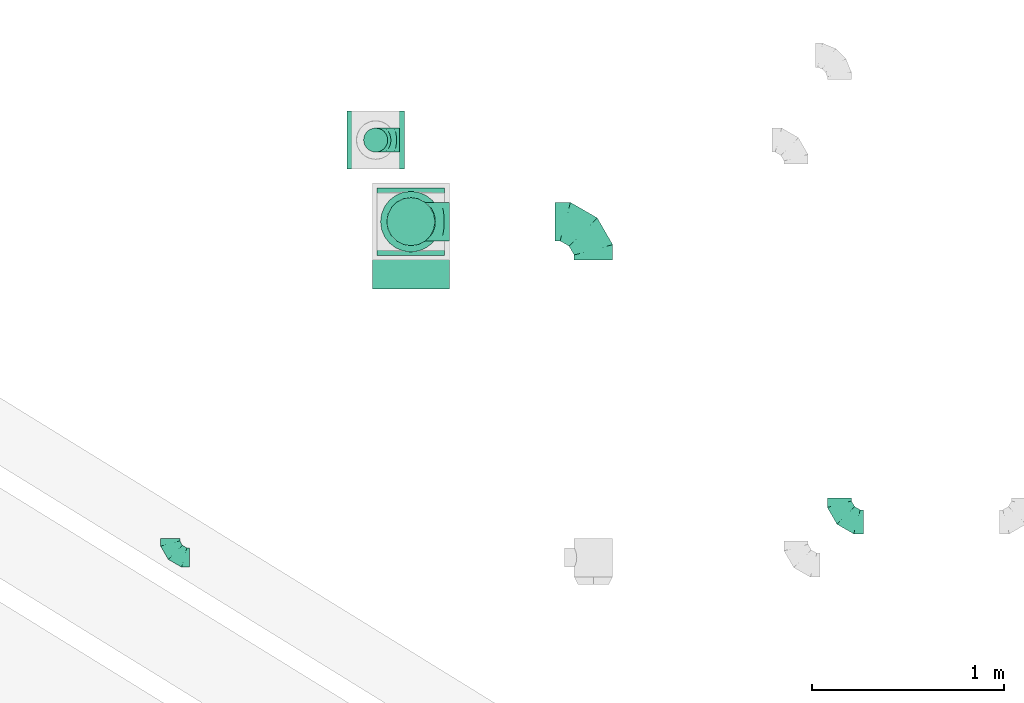
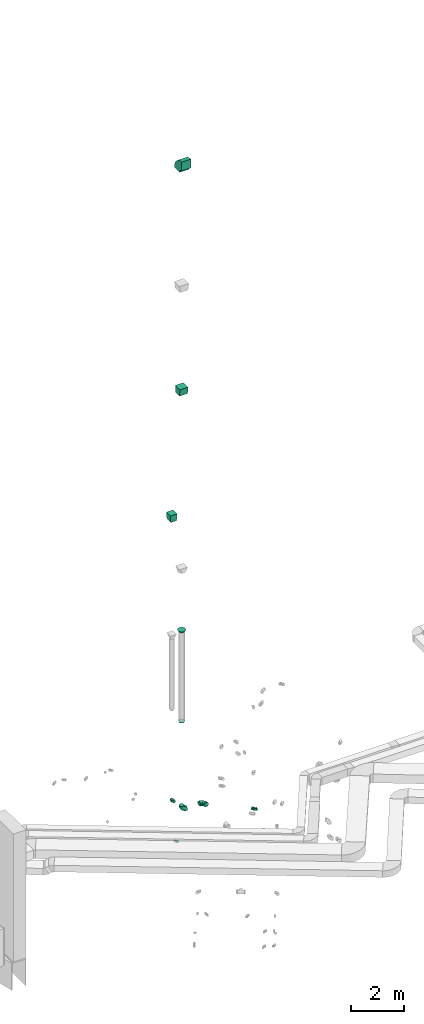
# One storey, part 38 of 97: 10 flow fittings.
"""IFC2X3 building model written with IfcOpenShell, lengths in millimetres."""

from ifc_helpers import new_model, entity, si_unit, converted_unit, derived_unit, direction, frame, frame_2d, origin, place, context, subcontext, project, spatial, polyline, circle_curve, parameter, trimmed, segment, composite_curve, outline, extrude, faceted_brep, source, transform, mapped, material, type_object, type_shapes, element, save


model = new_model("IFC2X3")

# Units and contexts
model_context = context("Model", 3, precision=0.01, world=origin(), true_north=direction((6.12303176911189e-17, 1.0)))
body_context = subcontext(model_context, "Body", "Model", "MODEL_VIEW")
ifc_project = project(units=[si_unit("LENGTHUNIT", "METRE", prefix="MILLI"), si_unit("AREAUNIT", "SQUARE_METRE"), si_unit("VOLUMEUNIT", "CUBIC_METRE"), converted_unit("PLANEANGLEUNIT", "DEGREE", entity("IfcRatioMeasure", 0.0174532925199433), si_unit("PLANEANGLEUNIT", "RADIAN"), dimensions=[0, 0, 0, 0, 0, 0, 0]), si_unit("MASSUNIT", "GRAM", prefix="KILO"), derived_unit("MASSDENSITYUNIT", [(si_unit("MASSUNIT", "GRAM", prefix="KILO"), 1), (si_unit("LENGTHUNIT", "METRE"), -3)]), derived_unit("MOMENTOFINERTIAUNIT", [(si_unit("LENGTHUNIT", "METRE"), 4)]), si_unit("TIMEUNIT", "SECOND"), si_unit("FREQUENCYUNIT", "HERTZ"), si_unit("THERMODYNAMICTEMPERATUREUNIT", "DEGREE_CELSIUS"), derived_unit("THERMALTRANSMITTANCEUNIT", [(si_unit("MASSUNIT", "GRAM", prefix="KILO"), 1), (si_unit("THERMODYNAMICTEMPERATUREUNIT", "KELVIN"), -1), (si_unit("TIMEUNIT", "SECOND"), -3)]), derived_unit("VOLUMETRICFLOWRATEUNIT", [(si_unit("LENGTHUNIT", "METRE"), 3), (si_unit("TIMEUNIT", "SECOND"), -1)]), derived_unit("MASSFLOWRATEUNIT", [(si_unit("MASSUNIT", "GRAM", prefix="KILO"), 1), (si_unit("TIMEUNIT", "SECOND"), -1)]), derived_unit("ROTATIONALFREQUENCYUNIT", [(si_unit("TIMEUNIT", "SECOND"), -1)]), si_unit("ELECTRICCURRENTUNIT", "AMPERE"), si_unit("ELECTRICVOLTAGEUNIT", "VOLT"), si_unit("POWERUNIT", "WATT"), si_unit("FORCEUNIT", "NEWTON", prefix="KILO"), si_unit("ILLUMINANCEUNIT", "LUX"), si_unit("LUMINOUSFLUXUNIT", "LUMEN"), si_unit("LUMINOUSINTENSITYUNIT", "CANDELA"), derived_unit("USERDEFINED", [(si_unit("MASSUNIT", "GRAM", prefix="KILO"), -1), (si_unit("LENGTHUNIT", "METRE"), -2), (si_unit("TIMEUNIT", "SECOND"), 3), (si_unit("LUMINOUSFLUXUNIT", "LUMEN"), 1)]), derived_unit("LINEARVELOCITYUNIT", [(si_unit("LENGTHUNIT", "METRE"), 1), (si_unit("TIMEUNIT", "SECOND"), -1)]), si_unit("PRESSUREUNIT", "PASCAL"), derived_unit("USERDEFINED", [(si_unit("LENGTHUNIT", "METRE"), -2), (si_unit("MASSUNIT", "GRAM", prefix="KILO"), 1), (si_unit("TIMEUNIT", "SECOND"), -2)]), derived_unit("LINEARFORCEUNIT", [(si_unit("MASSUNIT", "GRAM", prefix="KILO"), 1), (si_unit("LENGTHUNIT", "METRE"), 1), (si_unit("TIMEUNIT", "SECOND"), -2), (si_unit("LENGTHUNIT", "METRE"), -1)]), derived_unit("PLANARFORCEUNIT", [(si_unit("MASSUNIT", "GRAM", prefix="KILO"), 1), (si_unit("LENGTHUNIT", "METRE"), 1), (si_unit("TIMEUNIT", "SECOND"), -2), (si_unit("LENGTHUNIT", "METRE"), -2)])], contexts=[model_context])

# Site, building, storey
site_placement = place(None, origin())
site = spatial("IfcSite", under=ifc_project, at=site_placement, CompositionType="ELEMENT")
building_placement = place(site_placement, origin())
building = spatial("IfcBuilding", under=site, at=building_placement, CompositionType="ELEMENT")
storey_placement = place(building_placement, frame((0.0, 0.0, -4900.0)))
storey = spatial("IfcBuildingStorey", under=building, at=storey_placement, CompositionType="ELEMENT", Elevation=-4900.0)

# Flow fittings
ifc_material = material()
duct_fitting_type_1 = type_object("IfcDuctFittingType", PredefinedType="NOTDEFINED", material=ifc_material)
shared_shape_1 = source(origin(), body_context, "Body", "SweptSolid", [
    extrude(outline(polyline([(-139.1, -137.03), (161.94, -137.03), (137.03, 161.94), (-159.86, 112.11), (-139.1, -137.03)])), frame((150.0, -149.99, 0.0), z_axis=(-5.48503268975493e-05, 1.0, 0.0), x_axis=(0.996545756756143, 5.46608606086653e-05, 0.0830454797295822)), (5.46608606086653e-05, 4.55507171053196e-06, 1.0), 300.0),
])
type_shapes(duct_fitting_type_1, [shared_shape_1])
flow_fitting_1_placement = place(storey_placement, frame((8021.67, 14359.63, 16995.0), z_axis=(-1.0, 0.0, 0.0), x_axis=(0.0, 0.0, 1.0)))
element("IfcFlowFitting", 1, at=flow_fitting_1_placement, inside=storey, type_object=duct_fitting_type_1, material=ifc_material, context=body_context, shape_type="MappedRepresentation", body=[
    mapped(shared_shape_1, transform((0.0, 0.0, 0.0), scale=1.0)),
])
duct_fitting_type_2 = type_object("IfcDuctFittingType", PredefinedType="NOTDEFINED", material=ifc_material)
shared_shape_2 = source(origin(), body_context, "Body", "SweptSolid", [
    extrude(outline(polyline([(-137.03, -161.94), (164.01, -161.94), (134.95, 186.85), (-161.94, 137.03), (-137.03, -161.94)])), frame((150.0, 0.0, -175.0), z_axis=(0.0, 0.0, 1.0), x_axis=(0.996545758244879, -0.0830454798537418, 0.0)), (0.0, 0.0, 1.0), 350.0),
])
type_shapes(duct_fitting_type_2, [shared_shape_2])
flow_fitting_2_placement = place(storey_placement, frame((8204.69, 13935.69, 22980.0), z_axis=(-1.0, 0.0, 0.0), x_axis=(0.0, 0.0, 1.0)))
element("IfcFlowFitting", 2, at=flow_fitting_2_placement, inside=storey, type_object=duct_fitting_type_2, material=ifc_material, context=body_context, shape_type="MappedRepresentation", body=[
    mapped(shared_shape_2, transform((0.0, 0.0, 0.0), scale=1.0)),
])
duct_fitting_type_3 = type_object("IfcDuctFittingType", PredefinedType="NOTDEFINED", material=ifc_material)
shared_shape_3 = source(origin(), body_context, "Body", "Brep", [
    faceted_brep([(-100.0, 0.0, -50.0), (-100.0, -12.94, -48.3), (-100.0, -25.0, -43.3), (-100.0, -35.36, -35.36), (-100.0, -43.3, -25.0), (-100.0, -48.3, -12.94), (-100.0, -50.0, 0.0), (-100.0, -48.3, 12.94), (-100.0, -43.3, 25.0), (-100.0, -35.36, 35.36), (-100.0, -25.0, 43.3), (-100.0, -12.94, 48.3), (-100.0, 0.0, 50.0), (-100.0, 12.94, 48.3), (-100.0, 25.0, 43.3), (-100.0, 35.36, 35.36), (-100.0, 43.3, 25.0), (-100.0, 48.3, 12.94), (-100.0, 50.0, 0.0), (-100.0, 48.3, -12.94), (-100.0, 43.3, -25.0), (-100.0, 35.36, -35.36), (-100.0, 25.0, -43.3), (-100.0, 12.94, -48.3), (-76.67, 12.94, 48.3), (-79.9, 25.0, 43.3), (-73.21, 0.0, 50.0), (-82.68, 35.36, 35.36), (-86.15, 48.3, 12.94), (-86.6, 50.0, 0.0), (-84.81, 43.3, 25.0), (-84.81, 43.3, -25.0), (-82.68, 35.36, -35.36), (-86.15, 48.3, -12.94), (-76.67, 12.94, -48.3), (-73.21, 0.0, -50.0), (-79.9, 25.0, -43.3), (-69.74, -12.94, -48.3), (-66.51, -25.0, -43.3), (-63.73, -35.36, -35.36), (-61.6, -43.3, -25.0), (-60.26, -48.3, -12.94), (-59.81, -50.0, 0.0), (-60.26, -48.3, 12.94), (-61.6, -43.3, 25.0), (-63.73, -35.36, 35.36), (-66.51, -25.0, 43.3), (-69.74, -12.94, 48.3), (-36.27, 36.27, 48.3), (-45.1, 45.1, 43.3), (-26.79, 26.79, 50.0), (-52.68, 52.68, 35.36), (-58.49, 58.49, 25.0), (-62.15, 62.15, 12.94), (-63.4, 63.4, 0.0), (-62.15, 62.15, -12.94), (-58.49, 58.49, -25.0), (-52.68, 52.68, -35.36), (-36.27, 36.27, -48.3), (-26.79, 26.79, -50.0), (-45.1, 45.1, -43.3), (-17.32, 17.32, -48.3), (-8.49, 8.49, -43.3), (-0.91, 0.91, -35.36), (4.9, -4.9, -25.0), (8.56, -8.56, -12.94), (9.81, -9.81, 0.0), (8.56, -8.56, 12.94), (4.9, -4.9, 25.0), (-0.91, 0.91, 35.36), (-8.49, 8.49, 43.3), (-17.32, 17.32, 48.3), (-12.94, 76.67, 48.3), (-25.0, 79.9, 43.3), (0.0, 73.21, 50.0), (-35.36, 82.68, 35.36), (-43.3, 84.81, 25.0), (-48.3, 86.15, 12.94), (-50.0, 86.6, 0.0), (-48.3, 86.15, -12.94), (-43.3, 84.81, -25.0), (-35.36, 82.68, -35.36), (-12.94, 76.67, -48.3), (0.0, 73.21, -50.0), (-25.0, 79.9, -43.3), (12.94, 69.74, -48.3), (25.0, 66.51, -43.3), (35.36, 63.73, -35.36), (43.3, 61.6, -25.0), (48.3, 60.26, -12.94), (50.0, 59.81, 0.0), (48.3, 60.26, 12.94), (43.3, 61.6, 25.0), (35.36, 63.73, 35.36), (25.0, 66.51, 43.3), (12.94, 69.74, 48.3), (-12.94, 100.0, -48.3), (-25.0, 100.0, -43.3), (-35.36, 100.0, -35.36), (-43.3, 100.0, -25.0), (-48.3, 100.0, -12.94), (-50.0, 100.0, 0.0), (-48.3, 100.0, 12.94), (-43.3, 100.0, 25.0), (-35.36, 100.0, 35.36), (-25.0, 100.0, 43.3), (-12.94, 100.0, 48.3), (0.0, 100.0, 50.0), (12.94, 100.0, 48.3), (25.0, 100.0, 43.3), (35.36, 100.0, 35.36), (43.3, 100.0, 25.0), (48.3, 100.0, 12.94), (50.0, 100.0, 0.0), (48.3, 100.0, -12.94), (43.3, 100.0, -25.0), (35.36, 100.0, -35.36), (25.0, 100.0, -43.3), (12.94, 100.0, -48.3), (0.0, 100.0, -50.0)], [[[0, 1, 2, 3, 4, 5, 6, 7, 8, 9, 10, 11, 12, 13, 14, 15, 16, 17, 18, 19, 20, 21, 22, 23]], [[24, 25, 14, 13]], [[26, 24, 13, 12]], [[14, 25, 27, 15]], [[28, 29, 18, 17]], [[30, 28, 17, 16]], [[15, 27, 30, 16]], [[20, 31, 32, 21]], [[33, 31, 20, 19]], [[18, 29, 33, 19]], [[34, 35, 0, 23]], [[36, 34, 23, 22]], [[32, 36, 22, 21]], [[2, 1, 37, 38]], [[3, 2, 38, 39]], [[0, 35, 37, 1]], [[5, 4, 40, 41]], [[6, 5, 41, 42]], [[3, 39, 40, 4]], [[6, 42, 43, 7]], [[7, 43, 44, 8]], [[8, 44, 45, 9]], [[10, 46, 47, 11]], [[11, 47, 26, 12]], [[10, 9, 45, 46]], [[48, 49, 25, 24]], [[50, 48, 24, 26]], [[27, 25, 49, 51]], [[52, 53, 28, 30]], [[51, 52, 30, 27]], [[29, 28, 53, 54]], [[55, 56, 31, 33]], [[54, 55, 33, 29]], [[57, 32, 31, 56]], [[58, 59, 35, 34]], [[60, 58, 34, 36]], [[57, 60, 36, 32]], [[37, 35, 59, 61]], [[38, 37, 61, 62]], [[39, 38, 62, 63]], [[41, 40, 64, 65]], [[42, 41, 65, 66]], [[63, 64, 40, 39]], [[43, 42, 66, 67]], [[44, 43, 67, 68]], [[68, 69, 45, 44]], [[46, 45, 69, 70]], [[47, 46, 70, 71]], [[26, 47, 71, 50]], [[72, 73, 49, 48]], [[74, 72, 48, 50]], [[51, 49, 73, 75]], [[76, 77, 53, 52]], [[75, 76, 52, 51]], [[54, 53, 77, 78]], [[79, 80, 56, 55]], [[78, 79, 55, 54]], [[81, 57, 56, 80]], [[82, 83, 59, 58]], [[84, 82, 58, 60]], [[81, 84, 60, 57]], [[61, 59, 83, 85]], [[62, 61, 85, 86]], [[63, 62, 86, 87]], [[65, 64, 88, 89]], [[66, 65, 89, 90]], [[87, 88, 64, 63]], [[67, 66, 90, 91]], [[68, 67, 91, 92]], [[92, 93, 69, 68]], [[70, 69, 93, 94]], [[71, 70, 94, 95]], [[50, 71, 95, 74]], [[96, 97, 98, 99, 100, 101, 102, 103, 104, 105, 106, 107, 108, 109, 110, 111, 112, 113, 114, 115, 116, 117, 118, 119]], [[72, 74, 107, 106]], [[73, 72, 106, 105]], [[75, 73, 105, 104]], [[77, 76, 103, 102]], [[78, 77, 102, 101]], [[75, 104, 103, 76]], [[78, 101, 100, 79]], [[79, 100, 99, 80]], [[80, 99, 98, 81]], [[96, 119, 83, 82]], [[97, 96, 82, 84]], [[84, 81, 98, 97]], [[83, 119, 118, 85]], [[85, 118, 117, 86]], [[86, 117, 116, 87]], [[88, 115, 114, 89]], [[89, 114, 113, 90]], [[87, 116, 115, 88]], [[91, 90, 113, 112]], [[92, 91, 112, 111]], [[93, 92, 111, 110]], [[95, 94, 109, 108]], [[74, 95, 108, 107]], [[110, 109, 94, 93]]]),
])
type_shapes(duct_fitting_type_3, [shared_shape_3])
flow_fitting_3_placement = place(storey_placement, frame((6954.03, 12190.19, 3950.0), z_axis=(0.0, 0.0, 1.0), x_axis=(0.0, -1.0, 0.0)))
element("IfcFlowFitting", 3, at=flow_fitting_3_placement, inside=storey, type_object=duct_fitting_type_3, material=ifc_material, context=body_context, shape_type="MappedRepresentation", body=[
    mapped(shared_shape_3, transform((0.0, 0.0, 0.0), scale=1.0)),
])
duct_fitting_type_4 = type_object("IfcDuctFittingType", PredefinedType="NOTDEFINED", material=ifc_material)
shared_shape_4 = source(origin(), body_context, "Body", "Brep", [
    faceted_brep([(-200.0, 0.0, -100.0), (-200.0, -25.88, -96.59), (-200.0, -50.0, -86.6), (-200.0, -70.71, -70.71), (-200.0, -86.6, -50.0), (-200.0, -96.59, -25.88), (-200.0, -100.0, 0.0), (-200.0, -96.59, 25.88), (-200.0, -86.6, 50.0), (-200.0, -70.71, 70.71), (-200.0, -50.0, 86.6), (-200.0, -25.88, 96.59), (-200.0, 0.0, 100.0), (-200.0, 25.88, 96.59), (-200.0, 50.0, 86.6), (-200.0, 70.71, 70.71), (-200.0, 86.6, 50.0), (-200.0, 96.59, 25.88), (-200.0, 100.0, 0.0), (-200.0, 96.59, -25.88), (-200.0, 86.6, -50.0), (-200.0, 70.71, -70.71), (-200.0, 50.0, -86.6), (-200.0, 25.88, -96.59), (-153.35, 25.88, 96.59), (-159.81, 50.0, 86.6), (-146.41, 0.0, 100.0), (-165.36, 70.71, 70.71), (-172.29, 96.59, 25.88), (-173.21, 100.0, 0.0), (-169.62, 86.6, 50.0), (-169.62, 86.6, -50.0), (-165.36, 70.71, -70.71), (-172.29, 96.59, -25.88), (-153.35, 25.88, -96.59), (-146.41, 0.0, -100.0), (-159.81, 50.0, -86.6), (-139.48, -25.88, -96.59), (-133.01, -50.0, -86.6), (-127.46, -70.71, -70.71), (-123.21, -86.6, -50.0), (-120.53, -96.59, -25.88), (-119.62, -100.0, 0.0), (-120.53, -96.59, 25.88), (-123.21, -86.6, 50.0), (-127.46, -70.71, 70.71), (-133.01, -50.0, 86.6), (-139.48, -25.88, 96.59), (-72.54, 72.54, 96.59), (-90.19, 90.19, 86.6), (-53.59, 53.59, 100.0), (-105.35, 105.35, 70.71), (-116.99, 116.99, 50.0), (-124.3, 124.3, 25.88), (-126.79, 126.79, 0.0), (-124.3, 124.3, -25.88), (-116.99, 116.99, -50.0), (-105.35, 105.35, -70.71), (-72.54, 72.54, -96.59), (-53.59, 53.59, -100.0), (-90.19, 90.19, -86.6), (-34.64, 34.64, -96.59), (-16.99, 16.99, -86.6), (-1.83, 1.83, -70.71), (9.81, -9.81, -50.0), (17.12, -17.12, -25.88), (19.62, -19.62, 0.0), (17.12, -17.12, 25.88), (9.81, -9.81, 50.0), (-1.83, 1.83, 70.71), (-16.99, 16.99, 86.6), (-34.64, 34.64, 96.59), (-25.88, 153.35, 96.59), (-50.0, 159.81, 86.6), (0.0, 146.41, 100.0), (-70.71, 165.36, 70.71), (-86.6, 169.62, 50.0), (-96.59, 172.29, 25.88), (-100.0, 173.21, 0.0), (-96.59, 172.29, -25.88), (-86.6, 169.62, -50.0), (-70.71, 165.36, -70.71), (-25.88, 153.35, -96.59), (0.0, 146.41, -100.0), (-50.0, 159.81, -86.6), (25.88, 139.48, -96.59), (50.0, 133.01, -86.6), (70.71, 127.46, -70.71), (86.6, 123.21, -50.0), (96.59, 120.53, -25.88), (100.0, 119.62, 0.0), (96.59, 120.53, 25.88), (86.6, 123.21, 50.0), (70.71, 127.46, 70.71), (50.0, 133.01, 86.6), (25.88, 139.48, 96.59), (-25.88, 200.0, -96.59), (-50.0, 200.0, -86.6), (-70.71, 200.0, -70.71), (-86.6, 200.0, -50.0), (-96.59, 200.0, -25.88), (-100.0, 200.0, 0.0), (-96.59, 200.0, 25.88), (-86.6, 200.0, 50.0), (-70.71, 200.0, 70.71), (-50.0, 200.0, 86.6), (-25.88, 200.0, 96.59), (0.0, 200.0, 100.0), (25.88, 200.0, 96.59), (50.0, 200.0, 86.6), (70.71, 200.0, 70.71), (86.6, 200.0, 50.0), (96.59, 200.0, 25.88), (100.0, 200.0, 0.0), (96.59, 200.0, -25.88), (86.6, 200.0, -50.0), (70.71, 200.0, -70.71), (50.0, 200.0, -86.6), (25.88, 200.0, -96.59), (0.0, 200.0, -100.0)], [[[0, 1, 2, 3, 4, 5, 6, 7, 8, 9, 10, 11, 12, 13, 14, 15, 16, 17, 18, 19, 20, 21, 22, 23]], [[24, 25, 14, 13]], [[26, 24, 13, 12]], [[14, 25, 27, 15]], [[28, 29, 18, 17]], [[30, 28, 17, 16]], [[15, 27, 30, 16]], [[20, 31, 32, 21]], [[33, 31, 20, 19]], [[18, 29, 33, 19]], [[34, 35, 0, 23]], [[36, 34, 23, 22]], [[32, 36, 22, 21]], [[1, 0, 35, 37]], [[2, 1, 37, 38]], [[38, 39, 3, 2]], [[5, 4, 40, 41]], [[6, 5, 41, 42]], [[39, 40, 4, 3]], [[6, 42, 43, 7]], [[7, 43, 44, 8]], [[8, 44, 45, 9]], [[9, 45, 46, 10]], [[10, 46, 47, 11]], [[26, 12, 11, 47]], [[48, 49, 25, 24]], [[50, 48, 24, 26]], [[27, 25, 49, 51]], [[52, 53, 28, 30]], [[51, 52, 30, 27]], [[29, 28, 53, 54]], [[55, 56, 31, 33]], [[54, 55, 33, 29]], [[32, 31, 56, 57]], [[58, 59, 35, 34]], [[60, 58, 34, 36]], [[57, 60, 36, 32]], [[37, 35, 59, 61]], [[38, 37, 61, 62]], [[39, 38, 62, 63]], [[41, 40, 64, 65]], [[42, 41, 65, 66]], [[63, 64, 40, 39]], [[43, 42, 66, 67]], [[44, 43, 67, 68]], [[68, 69, 45, 44]], [[46, 45, 69, 70]], [[47, 46, 70, 71]], [[26, 47, 71, 50]], [[72, 73, 49, 48]], [[74, 72, 48, 50]], [[51, 49, 73, 75]], [[76, 77, 53, 52]], [[75, 76, 52, 51]], [[54, 53, 77, 78]], [[79, 80, 56, 55]], [[78, 79, 55, 54]], [[57, 56, 80, 81]], [[82, 83, 59, 58]], [[84, 82, 58, 60]], [[81, 84, 60, 57]], [[61, 59, 83, 85]], [[62, 61, 85, 86]], [[63, 62, 86, 87]], [[65, 64, 88, 89]], [[66, 65, 89, 90]], [[87, 88, 64, 63]], [[67, 66, 90, 91]], [[68, 67, 91, 92]], [[92, 93, 69, 68]], [[70, 69, 93, 94]], [[71, 70, 94, 95]], [[50, 71, 95, 74]], [[96, 97, 98, 99, 100, 101, 102, 103, 104, 105, 106, 107, 108, 109, 110, 111, 112, 113, 114, 115, 116, 117, 118, 119]], [[72, 74, 107, 106]], [[73, 72, 106, 105]], [[75, 73, 105, 104]], [[102, 101, 78, 77]], [[103, 102, 77, 76]], [[75, 104, 103, 76]], [[78, 101, 100, 79]], [[79, 100, 99, 80]], [[80, 99, 98, 81]], [[84, 97, 96, 82]], [[82, 96, 119, 83]], [[84, 81, 98, 97]], [[118, 117, 86, 85]], [[119, 118, 85, 83]], [[116, 87, 86, 117]], [[88, 115, 114, 89]], [[89, 114, 113, 90]], [[115, 88, 87, 116]], [[91, 90, 113, 112]], [[92, 91, 112, 111]], [[111, 110, 93, 92]], [[95, 94, 109, 108]], [[74, 95, 108, 107]], [[110, 109, 94, 93]]]),
])
type_shapes(duct_fitting_type_4, [shared_shape_4])
for number, where, z_axis, x_axis in (
    (4, (9153.25, 13935.69, 3950.0), (0.0, 0.0, 1.0), (0.0, 1.0, 0.0)),
    (5, (8204.69, 13935.69, 3950.0), (0.0, 1.0, 0.0), (-1.0, 0.0, 0.0)),
):
    element("IfcFlowFitting", number, at=place(storey_placement, frame(where, z_axis=z_axis, x_axis=x_axis)), inside=storey, type_object=duct_fitting_type_4, material=ifc_material, context=body_context, shape_type="MappedRepresentation", body=[
        mapped(shared_shape_4, transform((0.0, 0.0, 0.0), scale=1.0)),
    ])
duct_fitting_type_5 = type_object("IfcDuctFittingType", PredefinedType="NOTDEFINED", material=ifc_material)
shared_shape_5 = source(origin(), body_context, "Body", "Brep", [
    faceted_brep([(-125.0, 0.0, -62.5), (-125.0, -16.18, -60.37), (-125.0, -31.25, -54.13), (-125.0, -44.19, -44.19), (-125.0, -54.13, -31.25), (-125.0, -60.37, -16.18), (-125.0, -62.5, 0.0), (-125.0, -60.37, 16.18), (-125.0, -54.13, 31.25), (-125.0, -44.19, 44.19), (-125.0, -31.25, 54.13), (-125.0, -16.18, 60.37), (-125.0, 0.0, 62.5), (-125.0, 16.18, 60.37), (-125.0, 31.25, 54.13), (-125.0, 44.19, 44.19), (-125.0, 54.13, 31.25), (-125.0, 60.37, 16.18), (-125.0, 62.5, 0.0), (-125.0, 60.37, -16.18), (-125.0, 54.13, -31.25), (-125.0, 44.19, -44.19), (-125.0, 31.25, -54.13), (-125.0, 16.18, -60.37), (-95.84, 16.18, 60.37), (-99.88, 31.25, 54.13), (-91.51, 0.0, 62.5), (-103.35, 44.19, 44.19), (-107.68, 60.37, 16.18), (-108.25, 62.5, 0.0), (-106.01, 54.13, 31.25), (-106.01, 54.13, -31.25), (-103.35, 44.19, -44.19), (-107.68, 60.37, -16.18), (-95.84, 16.18, -60.37), (-91.51, 0.0, -62.5), (-99.88, 31.25, -54.13), (-87.17, -16.18, -60.37), (-83.13, -31.25, -54.13), (-79.66, -44.19, -44.19), (-77.0, -54.13, -31.25), (-75.33, -60.37, -16.18), (-74.76, -62.5, 0.0), (-75.33, -60.37, 16.18), (-77.0, -54.13, 31.25), (-79.66, -44.19, 44.19), (-83.13, -31.25, 54.13), (-87.17, -16.18, 60.37), (-45.34, 45.34, 60.37), (-56.37, 56.37, 54.13), (-33.49, 33.49, 62.5), (-65.85, 65.85, 44.19), (-73.12, 73.12, 31.25), (-77.69, 77.69, 16.18), (-79.25, 79.25, 0.0), (-77.69, 77.69, -16.18), (-73.12, 73.12, -31.25), (-65.85, 65.85, -44.19), (-45.34, 45.34, -60.37), (-33.49, 33.49, -62.5), (-56.37, 56.37, -54.13), (-21.65, 21.65, -60.37), (-10.62, 10.62, -54.13), (-1.14, 1.14, -44.19), (6.13, -6.13, -31.25), (10.7, -10.7, -16.18), (12.26, -12.26, 0.0), (10.7, -10.7, 16.18), (6.13, -6.13, 31.25), (-1.14, 1.14, 44.19), (-10.62, 10.62, 54.13), (-21.65, 21.65, 60.37), (-16.18, 95.84, 60.37), (-31.25, 99.88, 54.13), (0.0, 91.51, 62.5), (-44.19, 103.35, 44.19), (-54.13, 106.01, 31.25), (-60.37, 107.68, 16.18), (-62.5, 108.25, 0.0), (-60.37, 107.68, -16.18), (-54.13, 106.01, -31.25), (-44.19, 103.35, -44.19), (-16.18, 95.84, -60.37), (0.0, 91.51, -62.5), (-31.25, 99.88, -54.13), (16.18, 87.17, -60.37), (31.25, 83.13, -54.13), (44.19, 79.66, -44.19), (54.13, 77.0, -31.25), (60.37, 75.33, -16.18), (62.5, 74.76, 0.0), (60.37, 75.33, 16.18), (54.13, 77.0, 31.25), (44.19, 79.66, 44.19), (31.25, 83.13, 54.13), (16.18, 87.17, 60.37), (-16.18, 125.0, -60.37), (-31.25, 125.0, -54.13), (-44.19, 125.0, -44.19), (-54.13, 125.0, -31.25), (-60.37, 125.0, -16.18), (-62.5, 125.0, 0.0), (-60.37, 125.0, 16.18), (-54.13, 125.0, 31.25), (-44.19, 125.0, 44.19), (-31.25, 125.0, 54.13), (-16.18, 125.0, 60.37), (0.0, 125.0, 62.5), (16.18, 125.0, 60.37), (31.25, 125.0, 54.13), (44.19, 125.0, 44.19), (54.13, 125.0, 31.25), (60.37, 125.0, 16.18), (62.5, 125.0, 0.0), (60.37, 125.0, -16.18), (54.13, 125.0, -31.25), (44.19, 125.0, -44.19), (31.25, 125.0, -54.13), (16.18, 125.0, -60.37), (0.0, 125.0, -62.5)], [[[0, 1, 2, 3, 4, 5, 6, 7, 8, 9, 10, 11, 12, 13, 14, 15, 16, 17, 18, 19, 20, 21, 22, 23]], [[24, 25, 14, 13]], [[26, 24, 13, 12]], [[14, 25, 27, 15]], [[28, 29, 18, 17]], [[30, 28, 17, 16]], [[15, 27, 30, 16]], [[20, 31, 32, 21]], [[33, 31, 20, 19]], [[18, 29, 33, 19]], [[34, 35, 0, 23]], [[36, 34, 23, 22]], [[21, 32, 36, 22]], [[1, 0, 35, 37]], [[2, 1, 37, 38]], [[38, 39, 3, 2]], [[5, 4, 40, 41]], [[6, 5, 41, 42]], [[39, 40, 4, 3]], [[6, 42, 43, 7]], [[7, 43, 44, 8]], [[45, 9, 8, 44]], [[9, 45, 46, 10]], [[10, 46, 47, 11]], [[26, 12, 11, 47]], [[48, 49, 25, 24]], [[50, 48, 24, 26]], [[27, 25, 49, 51]], [[52, 53, 28, 30]], [[51, 52, 30, 27]], [[29, 28, 53, 54]], [[55, 56, 31, 33]], [[54, 55, 33, 29]], [[57, 32, 31, 56]], [[58, 59, 35, 34]], [[60, 58, 34, 36]], [[57, 60, 36, 32]], [[37, 35, 59, 61]], [[38, 37, 61, 62]], [[39, 38, 62, 63]], [[41, 40, 64, 65]], [[42, 41, 65, 66]], [[63, 64, 40, 39]], [[43, 42, 66, 67]], [[44, 43, 67, 68]], [[68, 69, 45, 44]], [[46, 45, 69, 70]], [[47, 46, 70, 71]], [[26, 47, 71, 50]], [[72, 73, 49, 48]], [[74, 72, 48, 50]], [[51, 49, 73, 75]], [[76, 77, 53, 52]], [[75, 76, 52, 51]], [[54, 53, 77, 78]], [[79, 80, 56, 55]], [[78, 79, 55, 54]], [[81, 57, 56, 80]], [[82, 83, 59, 58]], [[84, 82, 58, 60]], [[81, 84, 60, 57]], [[61, 59, 83, 85]], [[62, 61, 85, 86]], [[63, 62, 86, 87]], [[65, 64, 88, 89]], [[66, 65, 89, 90]], [[87, 88, 64, 63]], [[67, 66, 90, 91]], [[68, 67, 91, 92]], [[92, 93, 69, 68]], [[70, 69, 93, 94]], [[71, 70, 94, 95]], [[50, 71, 95, 74]], [[96, 97, 98, 99, 100, 101, 102, 103, 104, 105, 106, 107, 108, 109, 110, 111, 112, 113, 114, 115, 116, 117, 118, 119]], [[72, 74, 107, 106]], [[73, 72, 106, 105]], [[75, 73, 105, 104]], [[77, 76, 103, 102]], [[78, 77, 102, 101]], [[75, 104, 103, 76]], [[78, 101, 100, 79]], [[79, 100, 99, 80]], [[80, 99, 98, 81]], [[96, 119, 83, 82]], [[97, 96, 82, 84]], [[84, 81, 98, 97]], [[83, 119, 118, 85]], [[85, 118, 117, 86]], [[116, 87, 86, 117]], [[88, 115, 114, 89]], [[89, 114, 113, 90]], [[115, 88, 87, 116]], [[91, 90, 113, 112]], [[92, 91, 112, 111]], [[111, 110, 93, 92]], [[95, 94, 109, 108]], [[74, 95, 108, 107]], [[110, 109, 94, 93]]]),
])
type_shapes(duct_fitting_type_5, [shared_shape_5])
for number, where, z_axis, x_axis in (
    (6, (10431.19, 12375.75, 4100.0), (0.0, 0.0, 1.0), (0.0, -1.0, 0.0)),
    (7, (8021.67, 14359.63, 4100.0), (0.0, 1.0, 0.0), (-1.0, 0.0, 0.0)),
):
    element("IfcFlowFitting", number, at=place(storey_placement, frame(where, z_axis=z_axis, x_axis=x_axis)), inside=storey, type_object=duct_fitting_type_5, material=ifc_material, context=body_context, shape_type="MappedRepresentation", body=[
        mapped(shared_shape_5, transform((0.0, 0.0, 0.0), scale=1.0)),
    ])
duct_fitting_type_6 = type_object("IfcDuctFittingType", PredefinedType="NOTDEFINED", material=ifc_material)
shared_shape_6 = source(origin(), body_context, "Body", "Brep", [
    faceted_brep([(50.0, -73.47, -101.13), (50.0, -38.63, -118.88), (50.0, 0.0, -125.0), (50.0, 38.63, -118.88), (50.0, 73.47, -101.13), (50.0, 101.13, -73.47), (50.0, 118.88, -38.63), (50.0, 125.0, 0.0), (50.0, 118.88, 38.63), (50.0, 101.13, 73.47), (50.0, 73.47, 101.13), (50.0, 38.63, 118.88), (50.0, 0.0, 125.0), (50.0, -38.63, 118.88), (50.0, -73.47, 101.13), (50.0, -101.13, 73.47), (50.0, -118.88, 38.63), (50.0, -125.0, 0.0), (50.0, -118.88, -38.63), (50.0, -101.13, -73.47), (0.0, 30.9, -95.11), (0.0, 0.0, -100.0), (0.0, -30.9, -95.11), (0.0, -58.78, -80.9), (0.0, -80.9, -58.78), (0.0, -95.11, -30.9), (0.0, -100.0, 0.0), (0.0, -95.11, 30.9), (0.0, -80.9, 58.78), (0.0, -58.78, 80.9), (0.0, -30.9, 95.11), (0.0, 0.0, 100.0), (0.0, 30.9, 95.11), (0.0, 58.78, 80.9), (0.0, 80.9, 58.78), (0.0, 95.11, 30.9), (0.0, 100.0, 0.0), (0.0, 95.11, -30.9), (0.0, 80.9, -58.78), (0.0, 58.78, -80.9)], [[[0, 1, 2, 3, 4, 5, 6, 7, 8, 9, 10, 11, 12, 13, 14, 15, 16, 17, 18, 19]], [[20, 21, 22, 23, 24, 25, 26, 27, 28, 29, 30, 31, 32, 33, 34, 35, 36, 37, 38, 39]], [[35, 34, 9, 8]], [[36, 35, 8, 7]], [[34, 33, 10, 9]], [[10, 33, 32, 11]], [[11, 32, 31, 12]], [[30, 29, 14, 13]], [[31, 30, 13, 12]], [[29, 28, 15, 14]], [[15, 28, 27, 16]], [[16, 27, 26, 17]], [[25, 24, 19, 18]], [[26, 25, 18, 17]], [[24, 23, 0, 19]], [[0, 23, 22, 1]], [[1, 22, 21, 2]], [[20, 39, 4, 3]], [[21, 20, 3, 2]], [[39, 38, 5, 4]], [[5, 38, 37, 6]], [[6, 37, 36, 7]]]),
])
type_shapes(duct_fitting_type_6, [shared_shape_6])
flow_fitting_4_placement = place(storey_placement, frame((8204.69, 13935.69, 7953.28), z_axis=(-1.0, 0.0, 0.0), x_axis=(0.0, 0.0, 1.0)))
element("IfcFlowFitting", 8, at=flow_fitting_4_placement, inside=storey, type_object=duct_fitting_type_6, material=ifc_material, context=body_context, shape_type="MappedRepresentation", body=[
    mapped(shared_shape_6, transform((0.0, 0.0, 0.0), scale=1.0)),
])
duct_fitting_type_7 = type_object("IfcDuctFittingType", PredefinedType="NOTDEFINED", material=ifc_material)
shared_shape_7 = source(origin(), body_context, "Body", "Brep", [
    faceted_brep([(65.0, -78.75, -136.4), (65.0, -40.76, -152.13), (65.0, 0.0, -157.5), (65.0, 40.76, -152.13), (65.0, 78.75, -136.4), (65.0, 111.37, -111.37), (65.0, 136.4, -78.75), (65.0, 152.13, -40.76), (65.0, 157.5, 0.0), (65.0, 152.13, 40.76), (65.0, 136.4, 78.75), (65.0, 111.37, 111.37), (65.0, 78.75, 136.4), (65.0, 40.76, 152.13), (65.0, 0.0, 157.5), (65.0, -40.76, 152.13), (65.0, -78.75, 136.4), (65.0, -111.37, 111.37), (65.0, -136.4, 78.75), (65.0, -152.13, 40.76), (65.0, -157.5, 0.0), (65.0, -152.13, -40.76), (65.0, -136.4, -78.75), (65.0, -111.37, -111.37), (0.0, 38.63, -118.88), (0.0, 0.0, -125.0), (0.0, -38.63, -118.88), (0.0, -73.47, -101.13), (0.0, -101.13, -73.47), (0.0, -118.88, -38.63), (0.0, -125.0, 0.0), (0.0, -118.88, 38.63), (0.0, -101.13, 73.47), (0.0, -73.47, 101.13), (0.0, -38.63, 118.88), (0.0, 0.0, 125.0), (0.0, 38.63, 118.88), (0.0, 73.47, 101.13), (0.0, 101.13, 73.47), (0.0, 118.88, 38.63), (0.0, 125.0, 0.0), (0.0, 118.88, -38.63), (0.0, 101.13, -73.47), (0.0, 73.47, -101.13)], [[[0, 1, 2, 3, 4, 5, 6, 7, 8, 9, 10, 11, 12, 13, 14, 15, 16, 17, 18, 19, 20, 21, 22, 23]], [[24, 25, 26, 27, 28, 29, 30, 31, 32, 33, 34, 35, 36, 37, 38, 39, 40, 41, 42, 43]], [[39, 38, 10]], [[40, 39, 9]], [[40, 9, 8]], [[9, 39, 10]], [[38, 11, 10]], [[36, 35, 13]], [[37, 36, 12]], [[12, 11, 37]], [[13, 12, 36]], [[35, 14, 13]], [[37, 11, 38]], [[34, 33, 16]], [[35, 34, 15]], [[35, 15, 14]], [[15, 34, 16]], [[33, 17, 16]], [[31, 30, 19]], [[32, 31, 18]], [[18, 17, 32]], [[19, 18, 31]], [[30, 20, 19]], [[32, 17, 33]], [[29, 28, 22]], [[30, 29, 21]], [[30, 21, 20]], [[21, 29, 22]], [[28, 23, 22]], [[26, 25, 1]], [[27, 26, 0]], [[0, 23, 27]], [[1, 0, 26]], [[25, 2, 1]], [[27, 23, 28]], [[24, 43, 4]], [[25, 24, 3]], [[25, 3, 2]], [[3, 24, 4]], [[43, 5, 4]], [[41, 40, 7]], [[42, 41, 6]], [[6, 5, 42]], [[7, 6, 41]], [[40, 8, 7]], [[42, 5, 43]]]),
])
type_shapes(duct_fitting_type_7, [shared_shape_7])
flow_fitting_5_placement = place(storey_placement, frame((8204.69, 13935.69, 12099.28), z_axis=(-1.0, 0.0, 0.0), x_axis=(0.0, 0.0, 1.0)))
element("IfcFlowFitting", 9, at=flow_fitting_5_placement, inside=storey, type_object=duct_fitting_type_7, material=ifc_material, context=body_context, shape_type="MappedRepresentation", body=[
    mapped(shared_shape_7, transform((0.0, 0.0, 0.0), scale=1.0)),
])
duct_fitting_type_8 = type_object("IfcDuctFittingType", PredefinedType="NOTDEFINED", material=ifc_material)
shared_shape_8 = source(origin(), body_context, "Body", "SweptSolid", [
    extrude(outline(composite_curve([segment(polyline([(-375.0, -175.0), (25.0, -175.0)]), True, "CONTINUOUS"), segment(trimmed(circle_curve(frame_2d((175.0, -175.0), x_axis=(0.0, 1.0)), 150.0), [parameter(0.0)], [parameter(90.0)], True, "PARAMETER"), False, "CONTINUOUS"), segment(polyline([(175.0, -25.0), (175.0, 375.0)]), True, "CONTINUOUS"), segment(trimmed(circle_curve(frame_2d((175.0, -175.0), x_axis=(0.0, 1.0)), 550.0), [parameter(0.0)], [parameter(90.0)], True, "PARAMETER"), True, "CONTINUOUS")], self_intersect=False)), frame((-175.0, 175.0, -200.0), z_axis=(0.0, 0.0, 1.0), x_axis=(-1.0, 0.0, 0.0)), (0.0, 0.0, 1.0), 400.0),
])
type_shapes(duct_fitting_type_8, [shared_shape_8])
flow_fitting_6_placement = place(storey_placement, frame((8204.69, 13935.69, 33600.0), z_axis=(1.0, 0.0, 0.0), x_axis=(0.0, 0.0, 1.0)))
element("IfcFlowFitting", 10, at=flow_fitting_6_placement, inside=storey, type_object=duct_fitting_type_8, material=ifc_material, context=body_context, shape_type="MappedRepresentation", body=[
    mapped(shared_shape_8, transform((0.0, 0.0, 0.0), scale=1.0)),
])

save(model, "model.ifc")
